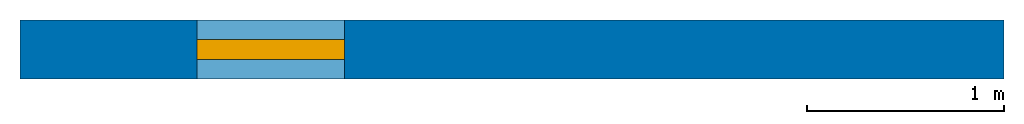
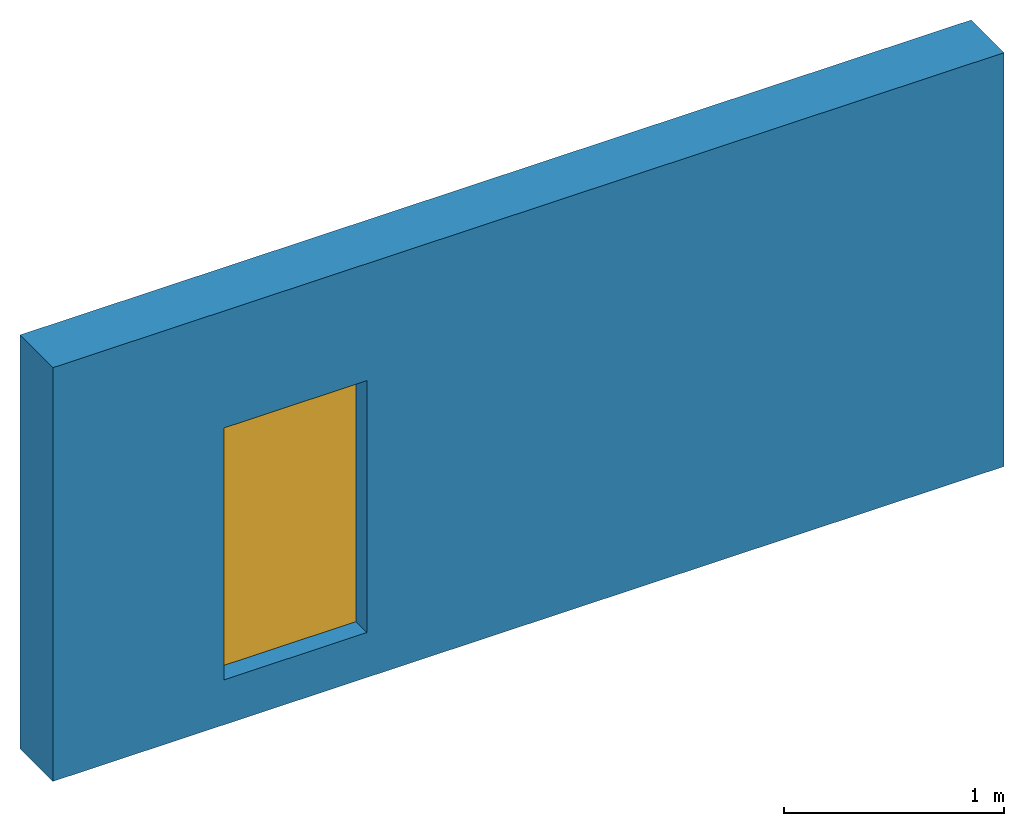
# One storey: 1 wall, 1 window, 1 opening.
"""IFC2X3 building model written with IfcOpenShell, lengths in metres."""

from ifc_helpers import new_model, entity, si_unit, converted_unit, frame, origin, origin_with_axes, place, context, project, spatial, polyline, outline, extrude, material, layer, layer_set, layer_usage, element, fill, save


model = new_model("IFC2X3")

# Units and contexts
model_context = context("Model", 3, precision=1e-05, world=origin())
ifc_project = project(units=[si_unit("LENGTHUNIT", "METRE"), si_unit("AREAUNIT", "SQUARE_METRE"), si_unit("VOLUMEUNIT", "CUBIC_METRE"), converted_unit("PLANEANGLEUNIT", "DEGREE", entity("IfcPlaneAngleMeasure", 0.01745), si_unit("PLANEANGLEUNIT", "RADIAN"), dimensions=[0, 0, 0, 0, 0, 0, 0]), si_unit("SOLIDANGLEUNIT", "STERADIAN"), si_unit("MASSUNIT", "GRAM"), si_unit("TIMEUNIT", "SECOND"), si_unit("THERMODYNAMICTEMPERATUREUNIT", "DEGREE_CELSIUS"), si_unit("LUMINOUSINTENSITYUNIT", "LUMEN")], contexts=[model_context])

# Site, building, storey
site_placement = place(None, origin_with_axes())
site = spatial("IfcSite", under=ifc_project, at=site_placement, CompositionType="ELEMENT")
building_placement = place(site_placement, origin_with_axes())
building = spatial("IfcBuilding", under=site, at=building_placement, Name="Default Building", CompositionType="ELEMENT")
storey_placement = place(building_placement, origin_with_axes())
storey = spatial("IfcBuildingStorey", under=building, at=storey_placement, Name="Default Building Storey", CompositionType="ELEMENT", Elevation=0.0)

# Wall, opening, window
ifc_material = material(Name="Name of the material used for the wall")
ifc_layer = layer(ifc_material, 0.3)
ifc_layer_set = layer_set([ifc_layer])
ifc_layer_usage = layer_usage(ifc_layer_set, "AXIS2", "POSITIVE", -0.15)
wall_placement = place(storey_placement, origin_with_axes())
wall = element("IfcWallStandardCase", 1, at=wall_placement, inside=storey, material=ifc_layer_usage, Name="Wall", context=model_context, shape_type="SweptSolid", body=[
    extrude(outline(polyline([(0.0, 0.0), (0.0, 0.3), (5.0, 0.3), (5.0, 0.0), (0.0, 0.0)])), origin_with_axes(), (0.0, 0.0, 1.0), 2.3),
])
opening_placement = place(wall_placement, frame((0.9, 0.0, 0.25), z_axis=(0.0, 0.0, 1.0), x_axis=(1.0, 0.0, 0.0)))
opening = element("IfcOpeningElement", 2, at=opening_placement, cuts=wall, Name="Opening Element", context=model_context, shape_type="SweptSolid", body=[
    extrude(outline(polyline([(0.0, 0.0), (0.0, 0.3), (0.75, 0.3), (0.75, 0.0), (0.0, 0.0)])), origin_with_axes(), (0.0, 0.0, 1.0), 1.4),
])
window_placement = place(opening_placement, frame((0.0, 0.1, 0.0), z_axis=(0.0, 0.0, 1.0), x_axis=(1.0, 0.0, 0.0)))
window = element("IfcWindow", 3, at=window_placement, inside=storey, Name="Window", OverallHeight=1.4, OverallWidth=0.75, context=model_context, shape_type="SweptSolid", body=[
    extrude(outline(polyline([(0.0, 0.0), (0.0, 0.1), (0.75, 0.1), (0.75, 0.0), (0.0, 0.0)])), origin_with_axes(), (0.0, 0.0, 1.0), 1.4),
])
fill(opening, window)

save(model, "model.ifc")
